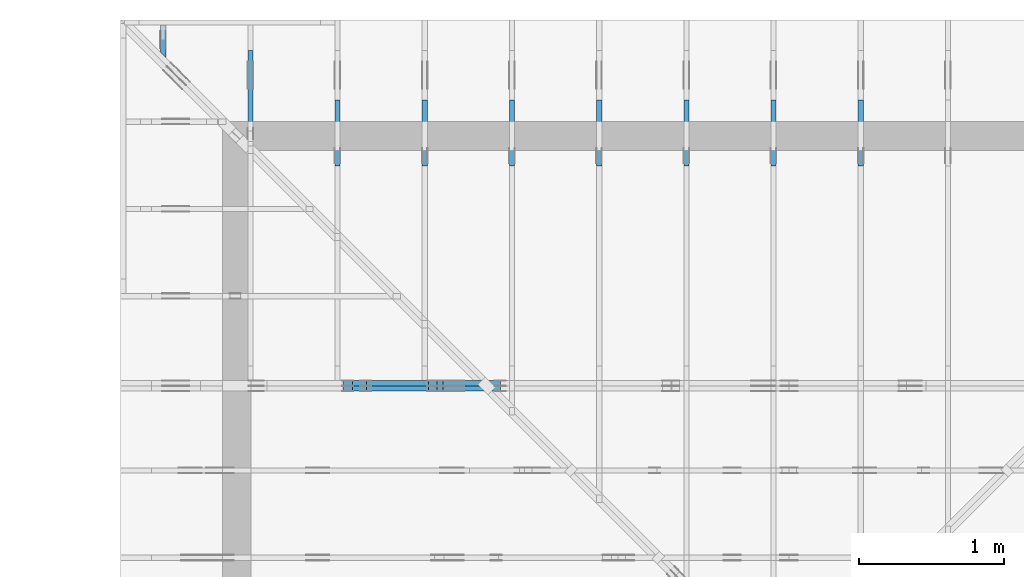
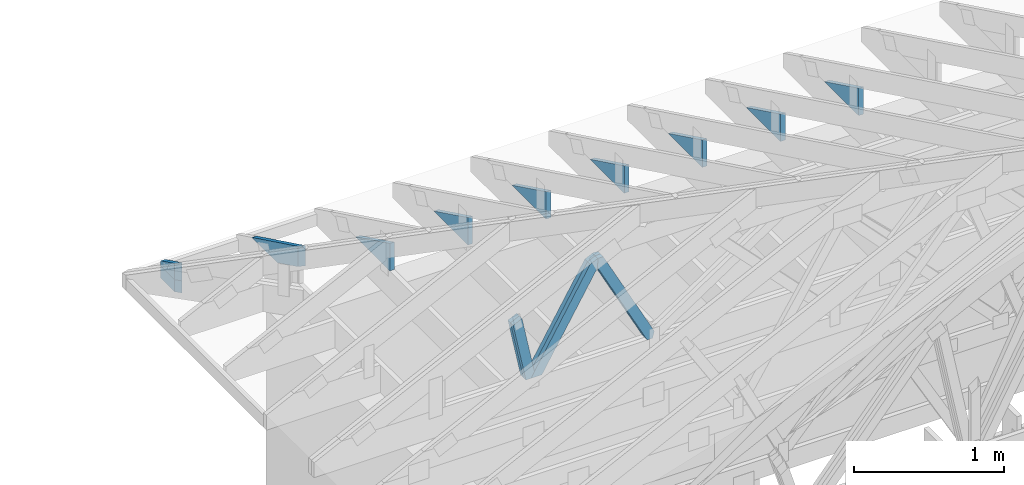
# One storey, part 47 of 159: 16 members, 10 elements without a shape of their own.
"""IFC2X3 building model written with IfcOpenShell, lengths in millimetres."""

from ifc_helpers import new_model, si_unit, frame, origin, origin_with_axes, origin_2d, place, context, project, spatial, faceted_brep, element, aggregate, save


model = new_model("IFC2X3")

# Units and contexts
model_context = context("Model", 3, precision=1e-05, world=origin())
plan_context = context("Plan", 2, precision=1e-05, world=origin_2d())
ifc_project = project(units=[si_unit("LENGTHUNIT", "METRE", prefix="MILLI"), si_unit("AREAUNIT", "SQUARE_METRE"), si_unit("VOLUMEUNIT", "CUBIC_METRE"), si_unit("SOLIDANGLEUNIT", "STERADIAN"), si_unit("PLANEANGLEUNIT", "RADIAN"), si_unit("MASSUNIT", "GRAM"), si_unit("TIMEUNIT", "SECOND"), si_unit("THERMODYNAMICTEMPERATUREUNIT", "DEGREE_CELSIUS"), si_unit("LUMINOUSINTENSITYUNIT", "LUMEN")], contexts=[model_context, plan_context])

# Site, building, storey
site_placement = place(None, origin_with_axes())
site = spatial("IfcSite", under=ifc_project, at=site_placement, CompositionType="ELEMENT")
building_placement = place(site_placement, origin_with_axes())
building = spatial("IfcBuilding", under=site, at=building_placement, Name="Plan 1", CompositionType="ELEMENT")
storey_placement = place(building_placement, origin_with_axes())
storey = spatial("IfcBuildingStorey", under=building, at=storey_placement, Name="Etasje 1", CompositionType="ELEMENT", Elevation=0.0)

# Assembly, members
assembly_1_placement = place(storey_placement, frame((19200.01266310149, 11417.999978540158, 0.0), z_axis=(1.2246063538223773e-16, 1.0, 6.123031769111886e-17), x_axis=(-1.0, 1.2246063538223773e-16, 0.0)))
assembly_1 = element("IfcElementAssembly", 1, at=assembly_1_placement, inside=storey, Name="V9 (1)", AssemblyPlace="FACTORY", PredefinedType="TRUSS")
member_1_placement = place(assembly_1_placement, frame((6990.062744470422, 999.2485918381567, -36.0), z_axis=(0.0, 0.0, 1.0), x_axis=(0.5106442206430858, -0.8597921143647548, 0.0)))
member_1 = element("IfcMember", 2, at=member_1_placement, Name="V9-D52", context=model_context, shape_type="Brep", body=[
    faceted_brep([(946.1886316871414, 72.99981255262173, 36.0), (55.580284619386475, 72.99981255262173, 36.0), (9.758263331605121e-05, 36.50012331499056, 36.0), (65.06524941222051, 0.0001720067257338087, 36.0), (902.8329925181561, 0.0001720067257338087, 36.0), (55.580284619386475, 72.99981255262173, 6.806396969215683e-15), (946.1886316871414, 72.99981255262173, 1.1587086102785745e-13), (902.8329925181561, 0.0001720067257338087, 1.1056150190782047e-13), (65.06524941222051, 0.0001720067257338087, 7.967931784324294e-15), (9.758263331605121e-05, 36.50012331499056, 1.1950031278155551e-20), (3.552713678800501e-15, 36.50000000112048, -7.888609052210118e-31), (3.552713678800501e-15, 36.50000000112048, 36.0), (55.580208793944635, 73.00000000000088, 36.0), (55.580208793944635, 73.00000000000088, -1.5777218104420236e-30), (65.06515947727986, -3.552713678800501e-15, -3.94430452610506e-31), (65.06515947727986, 0.0, 36.0), (1.7763568394002505e-15, 36.5000000011205, 36.0), (0.0, 36.5000000011205, -8.758115402030107e-47), (902.8328811920755, 2.0278803245901084e-12, 4.289819206961582e-29), (902.8328811920755, 2.0300846160269887e-12, 36.0), (65.06515947727985, -4.828666616239046e-14, 36.0), (65.06515947727985, -5.049095759927074e-14, 3.0915773743321593e-30), (946.1887430151243, 73.00000000000381, -1.8932661725304283e-29), (946.1887430151243, 73.00000000000381, 36.0), (902.8328811920753, 2.8421709430404007e-12, 36.0), (902.8328811920753, 2.8421709430404007e-12, -1.8932661725304283e-29), (55.58020879394463, 73.00000000000092, 0.0), (55.58020879394463, 73.00000000000092, 36.0), (946.1887430151246, 73.00000000000384, 36.0), (946.1887430151246, 73.00000000000384, 1.1832913578315177e-29)], [[[0, 1, 2, 3, 4]], [[5, 6, 7, 8, 9]], [[10, 11, 12, 13]], [[14, 15, 16, 17]], [[18, 19, 20, 21]], [[22, 23, 24, 25]], [[26, 27, 28, 29]]]),
])
member_2_placement = place(assembly_1_placement, frame((6990.062744470422, 999.2485918381567, -72.0), z_axis=(0.0, 0.0, 1.0), x_axis=(0.5106442206430858, -0.8597921143647548, 0.0)))
member_2 = element("IfcMember", 3, at=member_2_placement, Name="V9-D52", context=model_context, shape_type="Brep", body=[
    faceted_brep([(946.1886316871414, 72.99981255262173, 36.0), (55.580284619386475, 72.99981255262173, 36.0), (9.758263331605121e-05, 36.50012331499056, 36.0), (65.06524941222051, 0.0001720067257338087, 36.0), (902.8329925181561, 0.0001720067257338087, 36.0), (55.580284619386475, 72.99981255262173, 6.806396969215683e-15), (946.1886316871414, 72.99981255262173, 1.1587086102785745e-13), (902.8329925181561, 0.0001720067257338087, 1.1056150190782047e-13), (65.06524941222051, 0.0001720067257338087, 7.967931784324294e-15), (9.758263331605121e-05, 36.50012331499056, 1.1950031278155551e-20), (3.552713678800501e-15, 36.50000000112048, -7.888609052210118e-31), (3.552713678800501e-15, 36.50000000112048, 36.0), (55.580208793944635, 73.00000000000088, 36.0), (55.580208793944635, 73.00000000000088, -1.5777218104420236e-30), (65.06515947727986, -3.552713678800501e-15, -3.94430452610506e-31), (65.06515947727986, 0.0, 36.0), (1.7763568394002505e-15, 36.5000000011205, 36.0), (0.0, 36.5000000011205, -8.758115402030107e-47), (902.8328811920755, 2.0278803245901084e-12, 4.289819206961582e-29), (902.8328811920755, 2.0300846160269887e-12, 36.0), (65.06515947727985, -4.828666616239046e-14, 36.0), (65.06515947727985, -5.049095759927074e-14, 3.0915773743321593e-30), (946.1887430151243, 73.00000000000381, -1.8932661725304283e-29), (946.1887430151243, 73.00000000000381, 36.0), (902.8328811920753, 2.8421709430404007e-12, 36.0), (902.8328811920753, 2.8421709430404007e-12, -1.8932661725304283e-29), (55.58020879394463, 73.00000000000092, 0.0), (55.58020879394463, 73.00000000000092, 36.0), (946.1887430151246, 73.00000000000384, 36.0), (946.1887430151246, 73.00000000000384, 1.1832913578315177e-29)], [[[0, 1, 2, 3, 4]], [[5, 6, 7, 8, 9]], [[10, 11, 12, 13]], [[14, 15, 16, 17]], [[18, 19, 20, 21]], [[22, 23, 24, 25]], [[26, 27, 28, 29]]]),
])
member_3_placement = place(assembly_1_placement, frame((6989.180590354407, 1034.953088492729, -36.0), z_axis=(0.0, 0.0, 1.0), x_axis=(-0.4675598504132737, -0.8839614167380367, 0.0)))
member_3 = element("IfcMember", 4, at=member_3_placement, Name="V9-D56", context=model_context, shape_type="Brep", body=[
    faceted_brep([(879.9266117985553, 73.00009629057968, 36.0), (65.06511393787332, 73.00009629057968, 36.0), (0.0, 36.50014755695338, 36.0), (19.30624938974597, 5.126474025018979e-05, 36.0), (858.8513948263503, 5.126474025018979e-05, 36.0), (899.2328611883004, 36.50014755695338, 36.0), (65.06511393787332, 73.00009629057968, 7.967915194049658e-15), (879.9266117985553, 73.00009629057968, 1.0775637197059072e-13), (899.2328611883004, 36.50014755695338, 1.1012062753770684e-13), (858.8513948263503, 5.126474025018979e-05, 1.0517548750935597e-13), (19.30624938974597, 5.126474025018979e-05, 2.364255567116231e-15), (0.0, 36.50014755695338, 0.0), (5.4368783819924715e-05, 36.50000000114596, 5.502834851037532e-32), (5.436878382170107e-05, 36.50000000114596, 36.0), (65.06521384733512, 73.0, 36.0), (65.06521384733512, 73.0, 1.0737799203139622e-30), (19.306252826627315, 0.0, -2.781606346354003e-32), (19.306252826627315, 8.881784197001252e-16, 36.0), (5.436878381814836e-05, 36.50000000114597, 36.0), (5.4368783816372e-05, 36.50000000114597, -9.779235532435121e-32), (858.8514352306529, 5.841352538571096e-13, 1.9921862359692613e-29), (858.8514352306529, 5.863395452939899e-13, 36.0), (19.306252826627315, -5.109513376530466e-15, 36.0), (19.306252826627315, -7.313804813410746e-15, 4.478265922559743e-31), (899.2328611874366, 36.499999999999886, 6.310887241768095e-30), (899.2328611874366, 36.499999999999886, 36.0), (858.8514352306529, 7.389644451905042e-13, 36.0), (858.8514352306529, 7.389644451905042e-13, 6.310887241768095e-30), (879.9266627301996, 73.00000000000091, 6.310887241768095e-30), (879.9266627301996, 73.00000000000091, 36.0), (899.2328611874365, 36.5, 36.0), (899.2328611874365, 36.5, 6.310887241768095e-30), (65.06521384733513, 73.0, -7.888609052210118e-31), (65.06521384733513, 73.0, 36.0), (879.9266627301995, 73.00000000000085, 36.0), (879.9266627301995, 73.00000000000085, -3.944304526105059e-30)], [[[0, 1, 2, 3, 4, 5]], [[6, 7, 8, 9, 10, 11]], [[12, 13, 14, 15]], [[16, 17, 18, 19]], [[20, 21, 22, 23]], [[24, 25, 26, 27]], [[28, 29, 30, 31]], [[32, 33, 34, 35]]]),
])
member_4_placement = place(assembly_1_placement, frame((6989.180590354407, 1034.953088492729, -72.0), z_axis=(0.0, 0.0, 1.0), x_axis=(-0.4675598504132737, -0.8839614167380367, 0.0)))
member_4 = element("IfcMember", 5, at=member_4_placement, Name="V9-D56", context=model_context, shape_type="Brep", body=[
    faceted_brep([(879.9266117985553, 73.00009629057968, 36.0), (65.06511393787332, 73.00009629057968, 36.0), (0.0, 36.50014755695338, 36.0), (19.30624938974597, 5.126474025018979e-05, 36.0), (858.8513948263503, 5.126474025018979e-05, 36.0), (899.2328611883004, 36.50014755695338, 36.0), (65.06511393787332, 73.00009629057968, 7.967915194049658e-15), (879.9266117985553, 73.00009629057968, 1.0775637197059072e-13), (899.2328611883004, 36.50014755695338, 1.1012062753770684e-13), (858.8513948263503, 5.126474025018979e-05, 1.0517548750935597e-13), (19.30624938974597, 5.126474025018979e-05, 2.364255567116231e-15), (0.0, 36.50014755695338, 0.0), (5.4368783819924715e-05, 36.50000000114596, 5.502834851037532e-32), (5.436878382170107e-05, 36.50000000114596, 36.0), (65.06521384733512, 73.0, 36.0), (65.06521384733512, 73.0, 1.0737799203139622e-30), (19.306252826627315, 0.0, -2.781606346354003e-32), (19.306252826627315, 8.881784197001252e-16, 36.0), (5.436878381814836e-05, 36.50000000114597, 36.0), (5.4368783816372e-05, 36.50000000114597, -9.779235532435121e-32), (858.8514352306529, 5.841352538571096e-13, 1.9921862359692613e-29), (858.8514352306529, 5.863395452939899e-13, 36.0), (19.306252826627315, -5.109513376530466e-15, 36.0), (19.306252826627315, -7.313804813410746e-15, 4.478265922559743e-31), (899.2328611874366, 36.499999999999886, 6.310887241768095e-30), (899.2328611874366, 36.499999999999886, 36.0), (858.8514352306529, 7.389644451905042e-13, 36.0), (858.8514352306529, 7.389644451905042e-13, 6.310887241768095e-30), (879.9266627301996, 73.00000000000091, 6.310887241768095e-30), (879.9266627301996, 73.00000000000091, 36.0), (899.2328611874365, 36.5, 36.0), (899.2328611874365, 36.5, 6.310887241768095e-30), (65.06521384733513, 73.0, -7.888609052210118e-31), (65.06521384733513, 73.0, 36.0), (879.9266627301995, 73.00000000000085, 36.0), (879.9266627301995, 73.00000000000085, -3.944304526105059e-30)], [[[0, 1, 2, 3, 4, 5]], [[6, 7, 8, 9, 10, 11]], [[12, 13, 14, 15]], [[16, 17, 18, 19]], [[20, 21, 22, 23]], [[24, 25, 26, 27]], [[28, 29, 30, 31]], [[32, 33, 34, 35]]]),
])
member_5_placement = place(assembly_1_placement, frame((7571.746129740891, 215.65188668468227, -36.00000000000001), z_axis=(0.0, 0.0, 1.0), x_axis=(0.20131671299269044, 0.9795262023395896, 0.0)))
member_5 = element("IfcMember", 6, at=member_5_placement, Name="V9-D70", context=model_context, shape_type="Brep", body=[
    faceted_brep([(514.064415967081, 73.00000684933184, 36.0), (40.08385574758495, 73.00000684933184, 36.0), (0.0, 36.50026471266938, 36.0), (7.501701636736925, 0.0, 36.0), (495.340177884922, 0.0, 36.0), (40.08385574758495, 73.00000684933184, 4.908694443419215e-15), (514.064415967081, 73.00000684933184, 6.295265500672769e-14), (495.340177884922, 0.0, 6.065967291413821e-14), (7.501701636736925, 0.0, 9.186631488827766e-16), (0.0, 36.50026471266938, 0.0), (4.3890017423109384e-05, 36.500051161487136, 4.576142760274522e-32), (4.3890017423109384e-05, 36.500051161487136, 36.0), (40.083893075328206, 73.00005116149167, 36.0), (40.083893075328206, 73.00005116149167, -8.799928619917867e-31), (7.5016911217928754, 5.116149168316042e-05, -9.86076131526265e-32), (7.501691121792877, 5.116149168360451e-05, 36.0), (4.389001743110299e-05, 36.50005116148715, 36.0), (4.389001742932663e-05, 36.50005116148715, -4.930380657631324e-31), (495.3401900806143, 5.1161490726255645e-05, 2.9029338926324984e-30), (495.3401900806143, 5.1161490728459936e-05, 36.0), (7.501691121792874, 5.116149168464671e-05, 36.0), (7.501691121792874, 5.116149168244242e-05, 4.3963488720753553e-32), (514.064436698539, 73.00005116148985, 0.0), (514.064436698539, 73.00005116148985, 36.0), (495.34019008061443, 5.116149077366572e-05, 36.0), (495.34019008061443, 5.116149077366572e-05, 0.0), (40.083893075328206, 73.00005116149168, 0.0), (40.083893075328206, 73.00005116149168, 36.0), (514.0644366985389, 73.00005116148986, 36.0), (514.0644366985389, 73.00005116148986, 0.0)], [[[0, 1, 2, 3, 4]], [[5, 6, 7, 8, 9]], [[10, 11, 12, 13]], [[14, 15, 16, 17]], [[18, 19, 20, 21]], [[22, 23, 24, 25]], [[26, 27, 28, 29]]]),
])
member_6_placement = place(assembly_1_placement, frame((7571.746129740891, 215.65188668468227, -72.00000000000001), z_axis=(0.0, 0.0, 1.0), x_axis=(0.20131671299269044, 0.9795262023395896, 0.0)))
member_6 = element("IfcMember", 7, at=member_6_placement, Name="V9-D70", context=model_context, shape_type="Brep", body=[
    faceted_brep([(514.064415967081, 73.00000684933184, 36.0), (40.08385574758495, 73.00000684933184, 36.0), (0.0, 36.50026471266938, 36.0), (7.501701636736925, 0.0, 36.0), (495.340177884922, 0.0, 36.0), (40.08385574758495, 73.00000684933184, 4.908694443419215e-15), (514.064415967081, 73.00000684933184, 6.295265500672769e-14), (495.340177884922, 0.0, 6.065967291413821e-14), (7.501701636736925, 0.0, 9.186631488827766e-16), (0.0, 36.50026471266938, 0.0), (4.3890017423109384e-05, 36.500051161487136, 4.576142760274522e-32), (4.3890017423109384e-05, 36.500051161487136, 36.0), (40.083893075328206, 73.00005116149167, 36.0), (40.083893075328206, 73.00005116149167, -8.799928619917867e-31), (7.5016911217928754, 5.116149168316042e-05, -9.86076131526265e-32), (7.501691121792877, 5.116149168360451e-05, 36.0), (4.389001743110299e-05, 36.50005116148715, 36.0), (4.389001742932663e-05, 36.50005116148715, -4.930380657631324e-31), (495.3401900806143, 5.1161490726255645e-05, 2.9029338926324984e-30), (495.3401900806143, 5.1161490728459936e-05, 36.0), (7.501691121792874, 5.116149168464671e-05, 36.0), (7.501691121792874, 5.116149168244242e-05, 4.3963488720753553e-32), (514.064436698539, 73.00005116148985, 0.0), (514.064436698539, 73.00005116148985, 36.0), (495.34019008061443, 5.116149077366572e-05, 36.0), (495.34019008061443, 5.116149077366572e-05, 0.0), (40.083893075328206, 73.00005116149168, 0.0), (40.083893075328206, 73.00005116149168, 36.0), (514.0644366985389, 73.00005116148986, 36.0), (514.0644366985389, 73.00005116148986, 0.0)], [[[0, 1, 2, 3, 4]], [[5, 6, 7, 8, 9]], [[10, 11, 12, 13]], [[14, 15, 16, 17]], [[18, 19, 20, 21]], [[22, 23, 24, 25]], [[26, 27, 28, 29]]]),
])
aggregate(assembly_1, [member_1, member_2, member_3, member_4, member_5, member_6])

# Assembly, member
assembly_2_placement = place(storey_placement, frame((12075.022261404758, 13899.999978540158, 1.1021457184401395e-15), z_axis=(-1.0, 1.836909530733566e-16, 6.123031769111886e-17), x_axis=(-1.836909530733566e-16, -1.0, 0.0)))
assembly_2 = element("IfcElementAssembly", 8, at=assembly_2_placement, inside=storey, Name="S32 (63)", AssemblyPlace="FACTORY", PredefinedType="TRUSS")
member_7_placement = place(assembly_2_placement, frame((1006.0125131977736, 446.0, -36.0), z_axis=(0.0, 0.0, 1.0), x_axis=(-1.0, 4.091286229072899e-13, 0.0)))
member_7 = element("IfcMember", 9, at=member_7_placement, Name="S32-KI3", context=model_context, shape_type="Brep", body=[
    faceted_brep([(9.90651187748881e-07, 223.00000000000003, 36.0), (9.907423645927338e-07, 0.0, 36.0), (457.2177744281512, 223.00000000018707, 36.0), (9.90651187748881e-07, 223.00000000000003, 0.0), (457.2177744281512, 223.00000000018707, 0.0), (9.907423645927338e-07, 0.0, 0.0), (9.117684385273604e-11, -5.877471754111438e-39, 7.174648137343064e-43), (9.117904814417292e-11, 9.012988421914265e-28, 36.0), (-2.0173207722610032e-15, 223.00000000000003, 36.0), (-4.221612209141282e-15, 223.00000000000003, 2.58490656734279e-31), (457.21775667341757, 223.00000000018716, -6.034789990526598e-30), (457.21775667341757, 223.00000000018716, 36.0), (9.117587755497102e-11, 1.9812040197938888e-15, 36.0), (9.117684385273606e-11, 1.9387045606711586e-26, -8.236717378783049e-43), (0.0, 223.00000000000003, 0.0), (0.0, 223.00000000000003, 36.0), (457.2177566734176, 223.0000000001871, 36.0), (457.2177566734176, 223.0000000001871, 1.5777218104420236e-30)], [[[0, 1, 2]], [[3, 4, 5]], [[6, 7, 8, 9]], [[10, 11, 12, 13]], [[14, 15, 16, 17]]]),
])
aggregate(assembly_2, [member_7])

assembly_3_placement = place(storey_placement, frame((15075.022261404756, 13899.999978540158, 1.1021457184401395e-15), z_axis=(-1.0, 1.836909530733566e-16, 6.123031769111886e-17), x_axis=(-1.836909530733566e-16, -1.0, 0.0)))
assembly_3 = element("IfcElementAssembly", 10, at=assembly_3_placement, inside=storey, Name="S37 (66)", AssemblyPlace="FACTORY", PredefinedType="TRUSS")
member_8_placement = place(assembly_3_placement, frame((1006.012513197813, 446.0, -36.0), z_axis=(0.0, 0.0, 1.0), x_axis=(-1.0, 4.091286229072899e-13, 0.0)))
member_8 = element("IfcMember", 11, at=member_8_placement, Name="S37-KI3", context=model_context, shape_type="Brep", body=[
    faceted_brep([(9.906905233947327e-07, 223.00000000000003, 36.0), (9.907817002385855e-07, 0.0, 36.0), (457.2177744281905, 223.00000000018707, 36.0), (9.906905233947327e-07, 223.00000000000003, 0.0), (457.2177744281905, 223.00000000018707, 0.0), (9.907817002385855e-07, 0.0, 0.0), (9.117684385273604e-11, -5.877471754111438e-39, 7.174648137343064e-43), (9.117904814417292e-11, 9.012988421914265e-28, 36.0), (-2.0173207722610032e-15, 223.00000000000003, 36.0), (-4.221612209141282e-15, 223.00000000000003, 2.58490656734279e-31), (457.21775667345696, 223.00000000018724, -7.602347092007433e-30), (457.21775667345696, 223.00000000018724, 36.0), (9.117587755497102e-11, 1.981204019800351e-15, 36.0), (9.117684385273606e-11, 2.5849394142282115e-26, -1.4349296274686127e-42), (0.0, 223.00000000000003, 0.0), (0.0, 223.00000000000003, 36.0), (457.21775667345696, 223.0000000001871, 36.0), (457.21775667345696, 223.0000000001871, 1.5777218104420236e-30)], [[[0, 1, 2]], [[3, 4, 5]], [[6, 7, 8, 9]], [[10, 11, 12, 13]], [[14, 15, 16, 17]]]),
])
aggregate(assembly_3, [member_8])

assembly_4_placement = place(storey_placement, frame((14475.022261404756, 13899.999978540158, 1.1021457184401395e-15), z_axis=(-1.0, 1.836909530733566e-16, 6.123031769111886e-17), x_axis=(-1.836909530733566e-16, -1.0, 0.0)))
assembly_4 = element("IfcElementAssembly", 12, at=assembly_4_placement, inside=storey, Name="S36 (68)", AssemblyPlace="FACTORY", PredefinedType="TRUSS")
member_9_placement = place(assembly_4_placement, frame((1006.0125131978377, 446.0, -36.0), z_axis=(0.0, 0.0, 1.0), x_axis=(-1.0, 4.091286229072899e-13, 0.0)))
member_9 = element("IfcMember", 13, at=member_9_placement, Name="S36-KI3", context=model_context, shape_type="Brep", body=[
    faceted_brep([(9.90715307125356e-07, 223.00000000000003, 36.0), (9.908064839692088e-07, 0.0, 36.0), (457.2177744282153, 223.00000000018707, 36.0), (9.90715307125356e-07, 223.00000000000003, 0.0), (457.2177744282153, 223.00000000018707, 0.0), (9.908064839692088e-07, 0.0, 0.0), (9.117684385273604e-11, -5.877471754111438e-39, 7.174648137343064e-43), (9.117904814417292e-11, 9.012988421914265e-28, 36.0), (-2.0173207722610032e-15, 223.00000000000003, 36.0), (-4.221612209141282e-15, 223.00000000000003, 2.58490656734279e-31), (457.21775667348186, 223.00000000018684, 1.4485758254073996e-29), (457.21775667348186, 223.00000000018684, 36.0), (9.117587755497104e-11, 1.9812040197357276e-15, 36.0), (9.117684385273608e-11, -3.877409121342317e-26, 2.8698592549372254e-42), (0.0, 223.00000000000003, 0.0), (0.0, 223.00000000000003, 36.0), (457.21775667348174, 223.0000000001871, 36.0), (457.21775667348174, 223.0000000001871, 1.5777218104420236e-30)], [[[0, 1, 2]], [[3, 4, 5]], [[6, 7, 8, 9]], [[10, 11, 12, 13]], [[14, 15, 16, 17]]]),
])
aggregate(assembly_4, [member_9])

assembly_5_placement = place(storey_placement, frame((12675.022261404758, 13899.999978540158, 1.1021457184401395e-15), z_axis=(-1.0, 1.836909530733566e-16, 6.123031769111886e-17), x_axis=(-1.836909530733566e-16, -1.0, 0.0)))
assembly_5 = element("IfcElementAssembly", 14, at=assembly_5_placement, inside=storey, Name="S33 (69)", AssemblyPlace="FACTORY", PredefinedType="TRUSS")
member_10_placement = place(assembly_5_placement, frame((1006.0125131971656, 446.0, -36.0), z_axis=(0.0, 0.0, 1.0), x_axis=(-1.0, 4.091286229072899e-13, 0.0)))
member_10 = element("IfcMember", 15, at=member_10_placement, Name="S33-KI3", context=model_context, shape_type="Brep", body=[
    faceted_brep([(9.900431905407459e-07, 223.00000000000003, 36.0), (9.901343673845986e-07, 0.0, 36.0), (457.2177744275432, 223.00000000018707, 36.0), (9.900431905407459e-07, 223.00000000000003, 0.0), (457.2177744275432, 223.00000000018707, 0.0), (9.901343673845986e-07, 0.0, 0.0), (9.117684385273604e-11, -5.877471754111438e-39, 7.174648137343064e-43), (9.117904814417292e-11, 9.012988421914265e-28, 36.0), (-2.0173207722610032e-15, 223.00000000000003, 36.0), (-4.221612209141282e-15, 223.00000000000003, 2.58490656734279e-31), (457.21775667280974, 223.0000000001868, 1.9218923688306516e-29), (457.21775667280974, 223.0000000001868, 36.0), (9.117587755497104e-11, 1.9812040197292653e-15, 36.0), (9.117684385273608e-11, -4.52364397489937e-26, 3.587324068671532e-42), (0.0, 223.00000000000003, 0.0), (0.0, 223.00000000000003, 36.0), (457.2177566728096, 223.0000000001871, 36.0), (457.2177566728096, 223.0000000001871, 1.5777218104420236e-30)], [[[0, 1, 2]], [[3, 4, 5]], [[6, 7, 8, 9]], [[10, 11, 12, 13]], [[14, 15, 16, 17]]]),
])
aggregate(assembly_5, [member_10])

assembly_6_placement = place(storey_placement, frame((11475.022261404758, 13899.999978540158, 1.1021457184401395e-15), z_axis=(-1.0, 1.836909530733566e-16, 6.123031769111886e-17), x_axis=(-1.836909530733566e-16, -1.0, 0.0)))
assembly_6 = element("IfcElementAssembly", 16, at=assembly_6_placement, inside=storey, Name="S31 (70)", AssemblyPlace="FACTORY", PredefinedType="TRUSS")
member_11_placement = place(assembly_6_placement, frame((1006.012513197297, 446.0, -36.0), z_axis=(0.0, 0.0, 1.0), x_axis=(-1.0, 4.091286229072899e-13, 0.0)))
member_11 = element("IfcMember", 17, at=member_11_placement, Name="S31-KI3", context=model_context, shape_type="Brep", body=[
    faceted_brep([(9.90174612525152e-07, 223.00000000000003, 36.0), (9.902657893690048e-07, 0.0, 36.0), (457.2177744276746, 223.00000000018707, 36.0), (9.90174612525152e-07, 223.00000000000003, 0.0), (457.2177744276746, 223.00000000018707, 0.0), (9.902657893690048e-07, 0.0, 0.0), (9.117684385273604e-11, -5.877471754111438e-39, 7.174648137343064e-43), (9.117904814417292e-11, 9.012988421914265e-28, 36.0), (-2.0173207722610032e-15, 223.00000000000003, 36.0), (-4.221612209141282e-15, 223.00000000000003, 2.58490656734279e-31), (457.2177566729411, 223.000000000187, 5.019427393759713e-30), (457.2177566729411, 223.000000000187, 36.0), (9.117587755497102e-11, 1.9812040197486523e-15, 36.0), (9.117684385273606e-11, -2.5849394142282115e-26, 1.4349296274686127e-42), (0.0, 223.00000000000003, 0.0), (0.0, 223.00000000000003, 36.0), (457.21775667294105, 223.0000000001871, 36.0), (457.21775667294105, 223.0000000001871, 1.5777218104420236e-30)], [[[0, 1, 2]], [[3, 4, 5]], [[6, 7, 8, 9]], [[10, 11, 12, 13]], [[14, 15, 16, 17]]]),
])
aggregate(assembly_6, [member_11])

assembly_7_placement = place(storey_placement, frame((13275.022261404756, 13899.999978540158, 1.1021457184401395e-15), z_axis=(-1.0, 1.836909530733566e-16, 6.123031769111886e-17), x_axis=(-1.836909530733566e-16, -1.0, 0.0)))
assembly_7 = element("IfcElementAssembly", 18, at=assembly_7_placement, inside=storey, Name="S34 (71)", AssemblyPlace="FACTORY", PredefinedType="TRUSS")
member_12_placement = place(assembly_7_placement, frame((1006.0125131974626, 446.0, -36.0), z_axis=(0.0, 0.0, 1.0), x_axis=(-1.0, 4.091286229072899e-13, 0.0)))
member_12 = element("IfcMember", 19, at=member_12_placement, Name="S34-KI3", context=model_context, shape_type="Brep", body=[
    faceted_brep([(9.903401405608747e-07, 223.00000000000003, 36.0), (9.904313174047275e-07, 0.0, 36.0), (457.21777442784014, 223.00000000018707, 36.0), (9.903401405608747e-07, 223.00000000000003, 0.0), (457.21777442784014, 223.00000000018707, 0.0), (9.904313174047275e-07, 0.0, 0.0), (9.117684385273604e-11, -5.877471754111438e-39, 7.174648137343064e-43), (9.117904814417292e-11, 9.012988421914265e-28, 36.0), (-2.0173207722610032e-15, 223.00000000000003, 36.0), (-4.221612209141282e-15, 223.00000000000003, 2.58490656734279e-31), (457.2177566731067, 223.00000000018684, 1.6073644775269578e-29), (457.2177566731067, 223.00000000018684, 36.0), (9.117587755497104e-11, 1.9812040197357276e-15, 36.0), (9.117684385273608e-11, -3.877409121342317e-26, 2.2586013653469506e-42), (0.0, 223.00000000000003, 0.0), (0.0, 223.00000000000003, 36.0), (457.2177566731066, 223.0000000001871, 36.0), (457.2177566731066, 223.0000000001871, 1.5777218104420236e-30)], [[[0, 1, 2]], [[3, 4, 5]], [[6, 7, 8, 9]], [[10, 11, 12, 13]], [[14, 15, 16, 17]]]),
])
aggregate(assembly_7, [member_12])

assembly_8_placement = place(storey_placement, frame((10875.022261404756, 13899.999978540158, 1.1021457184401395e-15), z_axis=(-1.0, 1.836909530733566e-16, 6.123031769111886e-17), x_axis=(-1.836909530733566e-16, -1.0, 0.0)))
assembly_8 = element("IfcElementAssembly", 20, at=assembly_8_placement, inside=storey, Name="S30 (72)", AssemblyPlace="FACTORY", PredefinedType="TRUSS")
member_13_placement = place(assembly_8_placement, frame((276.0602080259688, 89.97847231204985, -36.00000021758473), z_axis=(0.0, 0.0, 1.0), x_axis=(0.8987940462991669, 0.43837114678907757, 0.0)))
member_13 = element("IfcMember", 21, at=member_13_placement, Name="S30-O74", context=model_context, shape_type="Brep", body=[
    faceted_brep([(722.3081234066613, 148.00000083082386, 2.2533374135491613e-06), (682.254456409325, 147.9999951378905, 35.999997187382746), (610.0700324582431, 3.2118452963914024e-07, 36.000000217584784), (650.1237024007742, -2.842170943040401e-14, 5.684341886080802e-14), (1.8932661725304283e-29, 148.000000322036, 2.1758472712463117e-07), (0.0, 148.0000003220361, 36.00000021758473), (682.2544555664061, 148.00000032203621, 36.00000021758473), (722.3081245422362, 148.0000003220361, 2.1758472712463117e-07), (303.4449880505614, 3.213495887166573e-07, 2.1758472712463117e-07), (303.4449880505614, 3.213495887166573e-07, 36.00000021758473), (1.633743010387434e-05, 148.00000186228982, 36.00000021758473), (1.633743010387434e-05, 148.00000186228982, 2.1758472712463117e-07), (650.1237023153378, 3.211627564191354e-07, 2.1758472712463117e-07), (610.0700333395079, 3.2116271002568303e-07, 36.00000021758473), (303.4449913778378, 3.211627663499292e-07, 36.00000021758473), (303.4449913778378, 3.211628201008782e-07, 2.1758472712463117e-07), (682.2544578122472, 148.00000032118447, 36.00000021758473), (2.513402444037638e-05, 148.00000032118447, 36.00000021758473), (303.44500194066507, 3.213495745058026e-07, 36.00000021758473), (610.0700324582432, 3.213495745058026e-07, 36.00000021758473), (1.995479999550298e-05, 148.00000032068147, 2.175847271246336e-07), (722.30812542355, 148.00000032068147, 2.1758481557894314e-07), (650.1237000695461, 3.2211562484008027e-07, 2.1758480673919256e-07), (303.44499676144073, 3.2211562484008027e-07, 2.1758476428469827e-07)], [[[0, 1, 2, 3]], [[4, 5, 6, 7]], [[8, 9, 10, 11]], [[12, 13, 14, 15]], [[16, 17, 18, 19]], [[20, 21, 22, 23]]]),
])
aggregate(assembly_8, [member_13])

assembly_9_placement = place(storey_placement, frame((13875.022261404758, 13899.999978540158, 1.1021457184401395e-15), z_axis=(-1.0, 1.836909530733566e-16, 6.123031769111886e-17), x_axis=(-1.836909530733566e-16, -1.0, 0.0)))
assembly_9 = element("IfcElementAssembly", 22, at=assembly_9_placement, inside=storey, Name="S35 (73)", AssemblyPlace="FACTORY", PredefinedType="TRUSS")
member_14_placement = place(assembly_9_placement, frame((1006.0125131976529, 446.0, -36.0), z_axis=(0.0, 0.0, 1.0), x_axis=(-1.0, 4.091286229072899e-13, 0.0)))
member_14 = element("IfcMember", 23, at=member_14_placement, Name="S35-KI3", context=model_context, shape_type="Brep", body=[
    faceted_brep([(9.905304523272207e-07, 223.00000000000003, 36.0), (9.906216291710734e-07, 0.0, 36.0), (457.21777442803045, 223.00000000018707, 36.0), (9.905304523272207e-07, 223.00000000000003, 0.0), (457.21777442803045, 223.00000000018707, 0.0), (9.906216291710734e-07, 0.0, 0.0), (9.117684385273604e-11, -5.877471754111438e-39, 7.174648137343064e-43), (9.117904814417292e-11, 9.012988421914265e-28, 36.0), (-2.0173207722610032e-15, 223.00000000000003, 36.0), (-4.221612209141282e-15, 223.00000000000003, 2.58490656734279e-31), (457.2177566732969, 223.0000000001871, -1.2914598495477022e-30), (457.2177566732969, 223.0000000001871, 36.0), (9.117587755497102e-11, 1.9812040197874264e-15, 36.0), (9.117684385273606e-11, 1.2924697071141057e-26, -7.174648137343064e-43), (0.0, 223.00000000000003, 0.0), (0.0, 223.00000000000003, 36.0), (457.2177566732969, 223.0000000001871, 36.0), (457.2177566732969, 223.0000000001871, 1.5777218104420236e-30)], [[[0, 1, 2]], [[3, 4, 5]], [[6, 7, 8, 9]], [[10, 11, 12, 13]], [[14, 15, 16, 17]]]),
])
aggregate(assembly_9, [member_14])

# Assembly, members
assembly_10_placement = place(storey_placement, frame((10275.022261404756, 13863.999978543303, 1.1021457184401395e-15), z_axis=(-1.0, 1.836909530733566e-16, 6.123031769111886e-17), x_axis=(-1.836909530733566e-16, -1.0, 0.0)))
assembly_10 = element("IfcElementAssembly", 24, at=assembly_10_placement, inside=storey, Name="S29 (82)", AssemblyPlace="FACTORY", PredefinedType="TRUSS")
member_15_placement = place(assembly_10_placement, frame((43.06472745047533, 9.704212413740827, -36.00000113062392), z_axis=(0.0, 0.0, 1.0), x_axis=(0.8987940462991669, 0.4383711467890776, 0.0)))
member_15 = element("IfcMember", 25, at=member_15_placement, Name="S29-O80", context=model_context, shape_type="Brep", body=[
    faceted_brep([(266.6730214085534, 133.79288914874445, 2.0388705905816096e-06), (226.6193544112138, 133.79289044330207, 36.000000036025526), (169.0612867069759, 15.781365612387894, 36.00000113062391), (201.41787264680366, 4.194802095014438e-06, 8.268195017535618e-07), (17.34124748559588, 133.79289245605844, 1.1306239215969072e-06), (17.34124748559588, 133.79289245605844, 36.00000113062392), (226.61935417504904, 133.7928924560584, 36.00000113062392), (266.6730231508791, 133.7928924560584, 1.1306239215969072e-06), (5.5068995763463136e-06, 98.23806314274256, 1.2338781587573069e-06), (5.5068995763463136e-06, 98.23806314274256, 36.00000113062392), (17.341254746833854, 133.79289307548606, 36.000000859565915), (17.341254746833854, 133.79289307548606, -7.888609052210118e-31), (201.41787237374626, 4.327980789753383e-06, 1.1306239215969072e-06), (169.0612867069762, 15.781365612387596, 36.00000113062392), (0.0, 98.23806460425644, 36.000001130623936), (7.105427357601002e-15, 98.23806460425644, 1.1306239215969072e-06), (226.61935402875324, 133.79289362752465, 36.00000113062392), (17.341254968694614, 133.79289362752465, 36.00000113062392), (7.410100877791592e-06, 98.23806116902851, 36.00000113062392), (169.0612867069759, 15.781365612387887, 36.00000113062392), (17.341252181568557, 133.792892456078, 1.130623923720528e-06), (266.67302403215456, 133.792892456078, 1.130623954253855e-06), (201.4178741908459, 0.0, 1.130623946262668e-06), (1.9881763883233816e-05, 98.23806381225587, 1.1306239215969095e-06)], [[[0, 1, 2, 3]], [[4, 5, 6, 7]], [[8, 9, 10, 11]], [[12, 13, 14, 15]], [[16, 17, 18, 19]], [[20, 21, 22, 23]]]),
])
member_16_placement = place(assembly_10_placement, frame((224.0979156494143, 98.00000236466197, -36.000001069760415), z_axis=(0.0, 0.0, 1.0), x_axis=(-1.0, 2.342906684632551e-15, 0.0)))
member_16 = element("IfcMember", 26, at=member_16_placement, Name="S29-U57", context=model_context, shape_type="Brep", body=[
    faceted_brep([(4.5186723093751296e-06, 2.3646619604310534e-06, 3.3947924325979355e-15), (36.000005588432714, 2.3646620519457424e-06, 36.00000106976041), (36.00000558843248, 98.00000236466205, 36.00000106976042), (4.518672298500311e-06, 98.00000236466197, 2.4164328629288625e-13), (224.09792123784678, 2.364662024991837e-06, 1.0697604153619977e-06), (224.09792123784678, 2.364662011208917e-06, 36.000001069760415), (36.000005588432714, 2.3646620457608023e-06, 36.000001069760415), (5.5884327139210654e-06, 2.3646620661565967e-06, 1.0697604153619977e-06), (5.5884320602217485e-06, 98.00000236466197, 1.0697604153619977e-06), (36.00000558843206, 98.00000236466197, 36.000001069760415), (224.09792123784612, 98.00000236466195, 36.000001069760415), (224.09792123784612, 98.00000236466195, 1.0697604153619977e-06), (224.09791564759226, 98.0000023463934, 2.034728638022898e-06), (224.09791564759226, 98.0000023463934, 36.000001069760415), (224.09791564759226, 0.0, 36.00000289666907), (224.09791564759226, 0.0, 3.5327937268903042e-06), (224.09792123784655, 98.00000236466249, 36.000001069760415), (36.00000558843249, 98.00000236466249, 36.000001069760415), (36.000005588432714, 2.364662051945743e-06, 36.000001069760415), (224.09792123784655, 2.364662051945743e-06, 36.000001069760415), (0.0, 98.00000236466197, 1.0697604153619977e-06), (224.09791564941406, 98.00000236466197, 1.0697604428051709e-06), (224.09791564759226, 2.364662492482239e-06, 1.0697604428051709e-06), (0.0, 2.364662492482239e-06, 1.0697604153619977e-06)], [[[0, 1, 2, 3]], [[4, 5, 6, 7]], [[8, 9, 10, 11]], [[12, 13, 14, 15]], [[16, 17, 18, 19]], [[20, 21, 22, 23]]]),
])
aggregate(assembly_10, [member_15, member_16])

save(model, "model.ifc")
